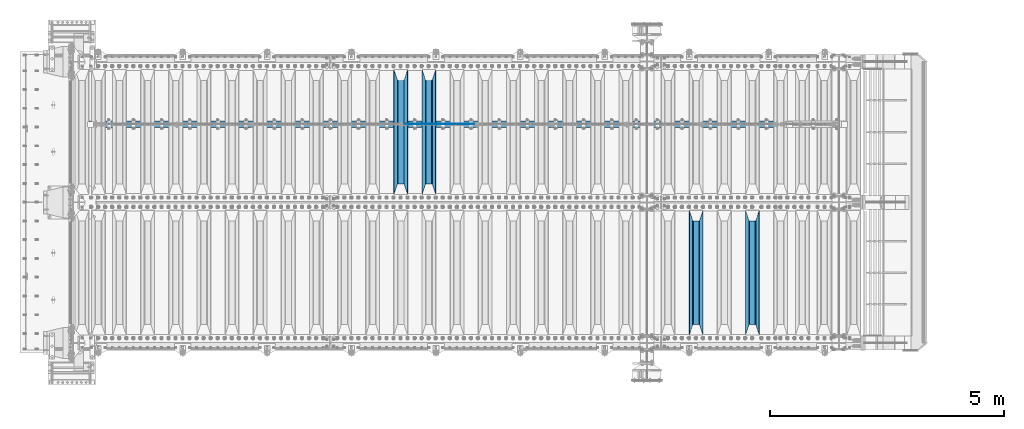
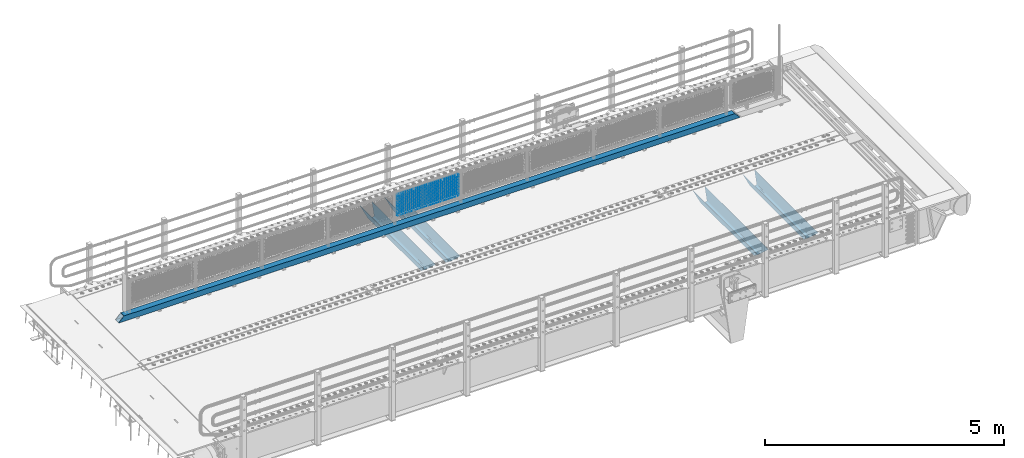
# One storey, part 102 of 208: 22 beams.
"""IFC2X3 building model written with IfcOpenShell, lengths in millimetres."""

from ifc_helpers import new_model, si_unit, frame, origin_with_axes, place, context, subcontext, project, spatial, faceted_brep, material, type_object, element, save


model = new_model("IFC2X3")

# Units and contexts
model_context = context("Model", 3, precision=1e-05, world=origin_with_axes())
body_context = subcontext(model_context, "Body", "Model", "MODEL_VIEW")
ifc_project = project(units=[si_unit("LENGTHUNIT", "METRE", prefix="MILLI"), si_unit("AREAUNIT", "SQUARE_METRE"), si_unit("VOLUMEUNIT", "CUBIC_METRE"), si_unit("MASSUNIT", "GRAM", prefix="KILO"), si_unit("TIMEUNIT", "SECOND"), si_unit("PLANEANGLEUNIT", "RADIAN"), si_unit("SOLIDANGLEUNIT", "STERADIAN"), si_unit("THERMODYNAMICTEMPERATUREUNIT", "DEGREE_CELSIUS"), si_unit("LUMINOUSINTENSITYUNIT", "LUMEN")], contexts=[model_context])

# Site, building, storey
site_placement = place(None, origin_with_axes())
site = spatial("IfcSite", under=ifc_project, at=site_placement, CompositionType="ELEMENT")
building_placement = place(site_placement, origin_with_axes())
building = spatial("IfcBuilding", under=site, at=building_placement, Name="Standard", CompositionType="ELEMENT")
storey_placement = place(building_placement, origin_with_axes())
storey = spatial("IfcBuildingStorey", under=building, at=storey_placement, Name="Undefined", CompositionType="ELEMENT", Elevation=0.0)

# Beams
ifc_material_1 = material(Name="STEEL/S355N")
beam_type_1 = type_object("IfcBeamType", PredefinedType="NOTDEFINED")
beam_1_placement = place(storey_placement, frame((-27950.0, 175.0, -115.0), z_axis=(0.0, 0.0, 1.0), x_axis=(0.0, 1.0, 0.0)))
element("IfcBeam", 1, at=beam_1_placement, inside=storey, type_object=beam_type_1, material=ifc_material_1, context=body_context, shape_type="Brep", body=[
    faceted_brep([(0.0, 150.0, 115.0), (0.0, 143.689999999999, 115.0), (2650.00000000297, 143.689999999999, 115.0), (2650.00000000297, 150.0, 115.0), (2650.00000000297, 142.059565218402, 110.0000000031), (2650.00000000297, 148.369565218403, 110.0000000031), (2441.90079219208, -80.1103600731112, -98.0992078077845), (2437.7588105432, -77.5672621345584, -102.241189456673), (2434.06523489746, -74.4080125315522, -105.934765102404), (2430.91086095089, -70.710272125576, -109.089139048974), (2428.37322971128, -66.5649389910068, -111.626770288588), (2426.51472138055, -62.0739139532889, -113.485278619323), (2425.38102192091, -57.3475956567672, -114.618978078955), (2424.99999999987, -52.5021667386536, -115.0), (2424.99999999987, 52.5021667386536, -115.0), (2425.38102192091, 57.3475956567672, -114.618978078955), (2426.51472138055, 62.0739139532889, -113.485278619323), (2428.37322971128, 66.5649389910068, -111.626770288588), (2430.91086095089, 70.710272125576, -109.089139048974), (2434.06523489746, 74.4080125315522, -105.934765102404), (2437.7588105432, 77.5672621345584, -102.241189456673), (2441.90079219208, 80.1103600731112, -98.0992078077846), (2446.38936140511, 81.9747917625791, -93.6106385947584), (2448.24948500409, 76.2713538057251, -91.7505149957729), (2444.62967112262, 74.76777986261, -95.3703288772456), (2441.28936334126, 72.7168944282894, -98.710636658607), (2438.31067330438, 70.1691124903846, -101.689326695487), (2435.76682334747, 67.1870637758839, -104.233176652398), (2433.72034654133, 63.8440531834895, -106.279653458539), (2432.22154950041, 60.222258798236, -107.778450499454), (2431.30727574265, 56.4107117849089, -108.692724257221), (2430.99999999987, 52.5031078186876, -109.0), (2430.99999999987, -52.5031078186876, -109.0), (2431.30727574265, -56.4107117849089, -108.692724257221), (2432.22154950041, -60.222258798236, -107.778450499454), (2433.72034654133, -63.8440531834895, -106.279653458539), (2435.76682334747, -67.1870637758839, -104.233176652398), (2438.31067330438, -70.1691124903846, -101.689326695487), (2441.28936334126, -72.7168944282894, -98.7106366586071), (2444.62967112262, -74.76777986261, -95.3703288772457), (2448.24948500409, -76.2713538057251, -91.7505149957729), (2650.00000000297, -142.059565218402, 110.0000000031), (2650.00000000297, -148.369565218403, 110.0000000031), (2446.38936140511, -81.9747917625791, -93.6106385947584), (2650.00000000297, -143.689999999999, 115.0), (2650.00000000297, -150.0, 115.0), (0.0, -143.689999999999, 115.0), (0.0, -150.0, 115.0), (0.0, -148.369565218261, 110.000000002663), (203.610638597421, -81.9747917625791, -93.6106385947584), (208.099207810448, -80.1103600731112, -98.0992078077845), (212.241189459336, -77.5672621345584, -102.241189456673), (215.934765105067, -74.4080125315522, -105.934765102404), (219.089139051637, -70.710272125576, -109.089139048974), (221.626770291251, -66.5649389910068, -111.626770288588), (223.485278621986, -62.0739139532889, -113.485278619323), (224.618978081618, -57.3475956567672, -114.618978078955), (225.000000002663, -52.5021667386536, -115.0), (225.000000002663, 52.5021667386536, -115.0), (224.618978081618, 57.3475956567672, -114.618978078955), (223.485278621986, 62.0739139532889, -113.485278619323), (221.626770291251, 66.5649389910068, -111.626770288588), (219.089139051637, 70.710272125576, -109.089139048974), (215.934765105067, 74.4080125315522, -105.934765102404), (212.241189459336, 77.5672621345584, -102.241189456673), (208.099207810448, 80.1103600731112, -98.0992078077846), (203.610638597421, 81.9747917625791, -93.6106385947584), (0.0, 148.369565218261, 110.000000002663), (0.0, 142.05956521826, 110.000000002663), (201.750514998436, 76.2713538057251, -91.7505149957729), (205.370328879908, 74.76777986261, -95.3703288772456), (208.71063666127, 72.7168944282894, -98.710636658607), (211.68932669815, 70.1691124903846, -101.689326695487), (214.233176655061, 67.1870637758839, -104.233176652398), (216.279653461202, 63.8440531834895, -106.279653458539), (217.778450502116, 60.222258798236, -107.778450499454), (218.692724259884, 56.4107117849089, -108.692724257221), (219.000000002663, 52.5031078186876, -109.0), (219.000000002663, -52.5031078186876, -109.0), (218.692724259884, -56.4107117849089, -108.692724257221), (217.778450502116, -60.222258798236, -107.778450499454), (216.279653461202, -63.8440531834895, -106.279653458539), (214.233176655061, -67.1870637758839, -104.233176652398), (211.68932669815, -70.1691124903846, -101.689326695487), (208.71063666127, -72.7168944282894, -98.7106366586071), (205.370328879908, -74.76777986261, -95.3703288772457), (201.750514998436, -76.2713538057251, -91.7505149957729), (0.0, -142.05956521826, 110.000000002663)], [[[0, 1, 2, 3]], [[3, 2, 4, 5]], [[6, 7, 8, 9, 10, 11, 12, 13, 14, 15, 16, 17, 18, 19, 20, 21, 22, 5, 4, 23, 24, 25, 26, 27, 28, 29, 30, 31, 32, 33, 34, 35, 36, 37, 38, 39, 40, 41, 42, 43]], [[44, 45, 42, 41]], [[46, 47, 45, 44]], [[43, 42, 45, 47, 48, 49]], [[6, 43, 49, 50]], [[7, 6, 50, 51]], [[8, 7, 51, 52]], [[9, 8, 52, 53]], [[10, 9, 53, 54]], [[11, 10, 54, 55]], [[12, 11, 55, 56]], [[13, 12, 56, 57]], [[14, 13, 57, 58]], [[15, 14, 58, 59]], [[16, 15, 59, 60]], [[17, 16, 60, 61]], [[18, 17, 61, 62]], [[19, 18, 62, 63]], [[20, 19, 63, 64]], [[21, 20, 64, 65]], [[22, 21, 65, 66]], [[0, 3, 5, 22, 66, 67]], [[1, 0, 67, 68]], [[23, 4, 2, 1, 68, 69]], [[24, 23, 69, 70]], [[25, 24, 70, 71]], [[26, 25, 71, 72]], [[27, 26, 72, 73]], [[28, 27, 73, 74]], [[29, 28, 74, 75]], [[30, 29, 75, 76]], [[31, 30, 76, 77]], [[32, 31, 77, 78]], [[33, 32, 78, 79]], [[34, 33, 79, 80]], [[35, 34, 80, 81]], [[36, 35, 81, 82]], [[37, 36, 82, 83]], [[38, 37, 83, 84]], [[39, 38, 84, 85]], [[40, 39, 85, 86]], [[46, 44, 41, 40, 86, 87]], [[47, 46, 87, 48]], [[86, 85, 84, 83, 82, 81, 80, 79, 78, 77, 76, 75, 74, 73, 72, 71, 70, 69, 68, 67, 66, 65, 64, 63, 62, 61, 60, 59, 58, 57, 56, 55, 54, 53, 52, 51, 50, 49, 48, 87]]]),
])
beam_2_placement = place(storey_placement, frame((-29150.0, 175.0, -115.0), z_axis=(0.0, 0.0, 1.0), x_axis=(0.0, 1.0, 0.0)))
element("IfcBeam", 2, at=beam_2_placement, inside=storey, type_object=beam_type_1, material=ifc_material_1, context=body_context, shape_type="Brep", body=[
    faceted_brep([(0.0, 150.0, 115.0), (0.0, 143.689999999999, 115.0), (2650.00000000297, 143.689999999999, 115.0), (2650.00000000297, 150.0, 115.0), (2650.00000000297, 142.059565218402, 110.0000000031), (2650.00000000297, 148.369565218403, 110.0000000031), (2441.90079219208, -80.1103600731112, -98.0992078077845), (2437.7588105432, -77.5672621345584, -102.241189456673), (2434.06523489746, -74.4080125315522, -105.934765102404), (2430.91086095089, -70.710272125576, -109.089139048974), (2428.37322971128, -66.5649389910068, -111.626770288588), (2426.51472138055, -62.0739139532889, -113.485278619323), (2425.38102192091, -57.3475956567672, -114.618978078955), (2424.99999999987, -52.5021667386536, -115.0), (2424.99999999987, 52.5021667386536, -115.0), (2425.38102192091, 57.3475956567672, -114.618978078955), (2426.51472138055, 62.0739139532889, -113.485278619323), (2428.37322971128, 66.5649389910068, -111.626770288588), (2430.91086095089, 70.710272125576, -109.089139048974), (2434.06523489746, 74.4080125315522, -105.934765102404), (2437.7588105432, 77.5672621345584, -102.241189456673), (2441.90079219208, 80.1103600731112, -98.0992078077846), (2446.38936140511, 81.9747917625791, -93.6106385947584), (2448.24948500409, 76.2713538057251, -91.7505149957729), (2444.62967112262, 74.76777986261, -95.3703288772456), (2441.28936334126, 72.7168944282894, -98.710636658607), (2438.31067330438, 70.1691124903846, -101.689326695487), (2435.76682334747, 67.1870637758839, -104.233176652398), (2433.72034654133, 63.8440531834895, -106.279653458539), (2432.22154950041, 60.222258798236, -107.778450499454), (2431.30727574265, 56.4107117849089, -108.692724257221), (2430.99999999987, 52.5031078186876, -109.0), (2430.99999999987, -52.5031078186876, -109.0), (2431.30727574265, -56.4107117849089, -108.692724257221), (2432.22154950041, -60.222258798236, -107.778450499454), (2433.72034654133, -63.8440531834895, -106.279653458539), (2435.76682334747, -67.1870637758839, -104.233176652398), (2438.31067330438, -70.1691124903846, -101.689326695487), (2441.28936334126, -72.7168944282894, -98.7106366586071), (2444.62967112262, -74.76777986261, -95.3703288772457), (2448.24948500409, -76.2713538057251, -91.7505149957729), (2650.00000000297, -142.059565218402, 110.0000000031), (2650.00000000297, -148.369565218403, 110.0000000031), (2446.38936140511, -81.9747917625791, -93.6106385947584), (2650.00000000297, -143.689999999999, 115.0), (2650.00000000297, -150.0, 115.0), (0.0, -143.689999999999, 115.0), (0.0, -150.0, 115.0), (0.0, -148.369565218261, 110.000000002663), (203.610638597421, -81.9747917625791, -93.6106385947584), (208.099207810448, -80.1103600731112, -98.0992078077845), (212.241189459336, -77.5672621345584, -102.241189456673), (215.934765105067, -74.4080125315522, -105.934765102404), (219.089139051637, -70.710272125576, -109.089139048974), (221.626770291251, -66.5649389910068, -111.626770288588), (223.485278621986, -62.0739139532889, -113.485278619323), (224.618978081618, -57.3475956567672, -114.618978078955), (225.000000002663, -52.5021667386536, -115.0), (225.000000002663, 52.5021667386536, -115.0), (224.618978081618, 57.3475956567672, -114.618978078955), (223.485278621986, 62.0739139532889, -113.485278619323), (221.626770291251, 66.5649389910068, -111.626770288588), (219.089139051637, 70.710272125576, -109.089139048974), (215.934765105067, 74.4080125315522, -105.934765102404), (212.241189459336, 77.5672621345584, -102.241189456673), (208.099207810448, 80.1103600731112, -98.0992078077846), (203.610638597421, 81.9747917625791, -93.6106385947584), (0.0, 148.369565218261, 110.000000002663), (0.0, 142.05956521826, 110.000000002663), (201.750514998436, 76.2713538057251, -91.7505149957729), (205.370328879908, 74.76777986261, -95.3703288772456), (208.71063666127, 72.7168944282894, -98.710636658607), (211.68932669815, 70.1691124903846, -101.689326695487), (214.233176655061, 67.1870637758839, -104.233176652398), (216.279653461202, 63.8440531834895, -106.279653458539), (217.778450502116, 60.222258798236, -107.778450499454), (218.692724259884, 56.4107117849089, -108.692724257221), (219.000000002663, 52.5031078186876, -109.0), (219.000000002663, -52.5031078186876, -109.0), (218.692724259884, -56.4107117849089, -108.692724257221), (217.778450502116, -60.222258798236, -107.778450499454), (216.279653461202, -63.8440531834895, -106.279653458539), (214.233176655061, -67.1870637758839, -104.233176652398), (211.68932669815, -70.1691124903846, -101.689326695487), (208.71063666127, -72.7168944282894, -98.7106366586071), (205.370328879908, -74.76777986261, -95.3703288772457), (201.750514998436, -76.2713538057251, -91.7505149957729), (0.0, -142.05956521826, 110.000000002663)], [[[0, 1, 2, 3]], [[3, 2, 4, 5]], [[6, 7, 8, 9, 10, 11, 12, 13, 14, 15, 16, 17, 18, 19, 20, 21, 22, 5, 4, 23, 24, 25, 26, 27, 28, 29, 30, 31, 32, 33, 34, 35, 36, 37, 38, 39, 40, 41, 42, 43]], [[44, 45, 42, 41]], [[46, 47, 45, 44]], [[43, 42, 45, 47, 48, 49]], [[6, 43, 49, 50]], [[7, 6, 50, 51]], [[8, 7, 51, 52]], [[9, 8, 52, 53]], [[10, 9, 53, 54]], [[11, 10, 54, 55]], [[12, 11, 55, 56]], [[13, 12, 56, 57]], [[14, 13, 57, 58]], [[15, 14, 58, 59]], [[16, 15, 59, 60]], [[17, 16, 60, 61]], [[18, 17, 61, 62]], [[19, 18, 62, 63]], [[20, 19, 63, 64]], [[21, 20, 64, 65]], [[22, 21, 65, 66]], [[0, 3, 5, 22, 66, 67]], [[1, 0, 67, 68]], [[23, 4, 2, 1, 68, 69]], [[24, 23, 69, 70]], [[25, 24, 70, 71]], [[26, 25, 71, 72]], [[27, 26, 72, 73]], [[28, 27, 73, 74]], [[29, 28, 74, 75]], [[30, 29, 75, 76]], [[31, 30, 76, 77]], [[32, 31, 77, 78]], [[33, 32, 78, 79]], [[34, 33, 79, 80]], [[35, 34, 80, 81]], [[36, 35, 81, 82]], [[37, 36, 82, 83]], [[38, 37, 83, 84]], [[39, 38, 84, 85]], [[40, 39, 85, 86]], [[46, 44, 41, 40, 86, 87]], [[47, 46, 87, 48]], [[86, 85, 84, 83, 82, 81, 80, 79, 78, 77, 76, 75, 74, 73, 72, 71, 70, 69, 68, 67, 66, 65, 64, 63, 62, 61, 60, 59, 58, 57, 56, 55, 54, 53, 52, 51, 50, 49, 48, 87]]]),
])
beam_3_placement = place(storey_placement, frame((-34850.0, 3175.0, -115.0), z_axis=(0.0, 0.0, 1.0), x_axis=(0.0, 1.0, 0.0)))
element("IfcBeam", 3, at=beam_3_placement, inside=storey, type_object=beam_type_1, material=ifc_material_1, context=body_context, shape_type="Brep", body=[
    faceted_brep([(0.0, 150.0, 115.0), (0.0, 143.689999999999, 115.0), (2650.00000000297, 143.689999999999, 115.0), (2650.00000000297, 150.0, 115.0), (2650.00000000297, 142.059565218402, 110.0000000031), (2650.00000000297, 148.369565218403, 110.0000000031), (2441.90079219208, -80.1103600731112, -98.0992078077845), (2437.7588105432, -77.5672621345584, -102.241189456673), (2434.06523489746, -74.4080125315522, -105.934765102404), (2430.91086095089, -70.710272125576, -109.089139048974), (2428.37322971128, -66.5649389910068, -111.626770288588), (2426.51472138055, -62.0739139532889, -113.485278619323), (2425.38102192091, -57.3475956567672, -114.618978078955), (2424.99999999987, -52.5021667386536, -115.0), (2424.99999999987, 52.5021667386536, -115.0), (2425.38102192091, 57.3475956567672, -114.618978078955), (2426.51472138055, 62.0739139532889, -113.485278619323), (2428.37322971128, 66.5649389910068, -111.626770288588), (2430.91086095089, 70.710272125576, -109.089139048974), (2434.06523489746, 74.4080125315522, -105.934765102404), (2437.7588105432, 77.5672621345584, -102.241189456673), (2441.90079219208, 80.1103600731112, -98.0992078077846), (2446.38936140511, 81.9747917625791, -93.6106385947584), (2448.24948500409, 76.2713538057251, -91.7505149957729), (2444.62967112262, 74.76777986261, -95.3703288772456), (2441.28936334126, 72.7168944282894, -98.710636658607), (2438.31067330438, 70.1691124903846, -101.689326695487), (2435.76682334747, 67.1870637758839, -104.233176652398), (2433.72034654133, 63.8440531834895, -106.279653458539), (2432.22154950041, 60.222258798236, -107.778450499454), (2431.30727574265, 56.4107117849089, -108.692724257221), (2430.99999999987, 52.5031078186876, -109.0), (2430.99999999987, -52.5031078186876, -109.0), (2431.30727574265, -56.4107117849089, -108.692724257221), (2432.22154950041, -60.222258798236, -107.778450499454), (2433.72034654133, -63.8440531834895, -106.279653458539), (2435.76682334747, -67.1870637758839, -104.233176652398), (2438.31067330438, -70.1691124903846, -101.689326695487), (2441.28936334126, -72.7168944282894, -98.7106366586071), (2444.62967112262, -74.76777986261, -95.3703288772457), (2448.24948500409, -76.2713538057251, -91.7505149957729), (2650.00000000297, -142.059565218402, 110.0000000031), (2650.00000000297, -148.369565218403, 110.0000000031), (2446.38936140511, -81.9747917625791, -93.6106385947584), (2650.00000000297, -143.689999999999, 115.0), (2650.00000000297, -150.0, 115.0), (0.0, -143.689999999999, 115.0), (0.0, -150.0, 115.0), (0.0, -148.369565218261, 110.000000002663), (203.610638597421, -81.9747917625791, -93.6106385947584), (208.099207810448, -80.1103600731112, -98.0992078077845), (212.241189459336, -77.5672621345584, -102.241189456673), (215.934765105067, -74.4080125315522, -105.934765102404), (219.089139051637, -70.710272125576, -109.089139048974), (221.626770291251, -66.5649389910068, -111.626770288588), (223.485278621986, -62.0739139532889, -113.485278619323), (224.618978081618, -57.3475956567672, -114.618978078955), (225.000000002663, -52.5021667386536, -115.0), (225.000000002663, 52.5021667386536, -115.0), (224.618978081618, 57.3475956567672, -114.618978078955), (223.485278621986, 62.0739139532889, -113.485278619323), (221.626770291251, 66.5649389910068, -111.626770288588), (219.089139051637, 70.710272125576, -109.089139048974), (215.934765105067, 74.4080125315522, -105.934765102404), (212.241189459336, 77.5672621345584, -102.241189456673), (208.099207810448, 80.1103600731112, -98.0992078077846), (203.610638597421, 81.9747917625791, -93.6106385947584), (0.0, 148.369565218261, 110.000000002663), (0.0, 142.05956521826, 110.000000002663), (201.750514998436, 76.2713538057251, -91.7505149957729), (205.370328879908, 74.76777986261, -95.3703288772456), (208.71063666127, 72.7168944282894, -98.710636658607), (211.68932669815, 70.1691124903846, -101.689326695487), (214.233176655061, 67.1870637758839, -104.233176652398), (216.279653461202, 63.8440531834895, -106.279653458539), (217.778450502116, 60.222258798236, -107.778450499454), (218.692724259884, 56.4107117849089, -108.692724257221), (219.000000002663, 52.5031078186876, -109.0), (219.000000002663, -52.5031078186876, -109.0), (218.692724259884, -56.4107117849089, -108.692724257221), (217.778450502116, -60.222258798236, -107.778450499454), (216.279653461202, -63.8440531834895, -106.279653458539), (214.233176655061, -67.1870637758839, -104.233176652398), (211.68932669815, -70.1691124903846, -101.689326695487), (208.71063666127, -72.7168944282894, -98.7106366586071), (205.370328879908, -74.76777986261, -95.3703288772457), (201.750514998436, -76.2713538057251, -91.7505149957729), (0.0, -142.05956521826, 110.000000002663)], [[[0, 1, 2, 3]], [[3, 2, 4, 5]], [[6, 7, 8, 9, 10, 11, 12, 13, 14, 15, 16, 17, 18, 19, 20, 21, 22, 5, 4, 23, 24, 25, 26, 27, 28, 29, 30, 31, 32, 33, 34, 35, 36, 37, 38, 39, 40, 41, 42, 43]], [[44, 45, 42, 41]], [[46, 47, 45, 44]], [[43, 42, 45, 47, 48, 49]], [[6, 43, 49, 50]], [[7, 6, 50, 51]], [[8, 7, 51, 52]], [[9, 8, 52, 53]], [[10, 9, 53, 54]], [[11, 10, 54, 55]], [[12, 11, 55, 56]], [[13, 12, 56, 57]], [[14, 13, 57, 58]], [[15, 14, 58, 59]], [[16, 15, 59, 60]], [[17, 16, 60, 61]], [[18, 17, 61, 62]], [[19, 18, 62, 63]], [[20, 19, 63, 64]], [[21, 20, 64, 65]], [[22, 21, 65, 66]], [[0, 3, 5, 22, 66, 67]], [[1, 0, 67, 68]], [[23, 4, 2, 1, 68, 69]], [[24, 23, 69, 70]], [[25, 24, 70, 71]], [[26, 25, 71, 72]], [[27, 26, 72, 73]], [[28, 27, 73, 74]], [[29, 28, 74, 75]], [[30, 29, 75, 76]], [[31, 30, 76, 77]], [[32, 31, 77, 78]], [[33, 32, 78, 79]], [[34, 33, 79, 80]], [[35, 34, 80, 81]], [[36, 35, 81, 82]], [[37, 36, 82, 83]], [[38, 37, 83, 84]], [[39, 38, 84, 85]], [[40, 39, 85, 86]], [[46, 44, 41, 40, 86, 87]], [[47, 46, 87, 48]], [[86, 85, 84, 83, 82, 81, 80, 79, 78, 77, 76, 75, 74, 73, 72, 71, 70, 69, 68, 67, 66, 65, 64, 63, 62, 61, 60, 59, 58, 57, 56, 55, 54, 53, 52, 51, 50, 49, 48, 87]]]),
])
beam_4_placement = place(storey_placement, frame((-35450.0, 3175.0, -115.0), z_axis=(0.0, 0.0, 1.0), x_axis=(0.0, 1.0, 0.0)))
element("IfcBeam", 4, at=beam_4_placement, inside=storey, type_object=beam_type_1, material=ifc_material_1, context=body_context, shape_type="Brep", body=[
    faceted_brep([(0.0, 150.0, 115.0), (0.0, 143.689999999999, 115.0), (2650.00000000297, 143.689999999999, 115.0), (2650.00000000297, 150.0, 115.0), (2650.00000000297, 142.059565218402, 110.0000000031), (2650.00000000297, 148.369565218403, 110.0000000031), (2441.90079219208, -80.1103600731112, -98.0992078077845), (2437.7588105432, -77.5672621345584, -102.241189456673), (2434.06523489746, -74.4080125315522, -105.934765102404), (2430.91086095089, -70.710272125576, -109.089139048974), (2428.37322971128, -66.5649389910068, -111.626770288588), (2426.51472138055, -62.0739139532889, -113.485278619323), (2425.38102192091, -57.3475956567672, -114.618978078955), (2424.99999999987, -52.5021667386536, -115.0), (2424.99999999987, 52.5021667386536, -115.0), (2425.38102192091, 57.3475956567672, -114.618978078955), (2426.51472138055, 62.0739139532889, -113.485278619323), (2428.37322971128, 66.5649389910068, -111.626770288588), (2430.91086095089, 70.710272125576, -109.089139048974), (2434.06523489746, 74.4080125315522, -105.934765102404), (2437.7588105432, 77.5672621345584, -102.241189456673), (2441.90079219208, 80.1103600731112, -98.0992078077846), (2446.38936140511, 81.9747917625791, -93.6106385947584), (2448.24948500409, 76.2713538057251, -91.7505149957729), (2444.62967112262, 74.76777986261, -95.3703288772456), (2441.28936334126, 72.7168944282894, -98.710636658607), (2438.31067330438, 70.1691124903846, -101.689326695487), (2435.76682334747, 67.1870637758839, -104.233176652398), (2433.72034654133, 63.8440531834895, -106.279653458539), (2432.22154950041, 60.222258798236, -107.778450499454), (2431.30727574265, 56.4107117849089, -108.692724257221), (2430.99999999987, 52.5031078186876, -109.0), (2430.99999999987, -52.5031078186876, -109.0), (2431.30727574265, -56.4107117849089, -108.692724257221), (2432.22154950041, -60.222258798236, -107.778450499454), (2433.72034654133, -63.8440531834895, -106.279653458539), (2435.76682334747, -67.1870637758839, -104.233176652398), (2438.31067330438, -70.1691124903846, -101.689326695487), (2441.28936334126, -72.7168944282894, -98.7106366586071), (2444.62967112262, -74.76777986261, -95.3703288772457), (2448.24948500409, -76.2713538057251, -91.7505149957729), (2650.00000000297, -142.059565218402, 110.0000000031), (2650.00000000297, -148.369565218403, 110.0000000031), (2446.38936140511, -81.9747917625791, -93.6106385947584), (2650.00000000297, -143.689999999999, 115.0), (2650.00000000297, -150.0, 115.0), (0.0, -143.689999999999, 115.0), (0.0, -150.0, 115.0), (0.0, -148.369565218261, 110.000000002663), (203.610638597421, -81.9747917625791, -93.6106385947584), (208.099207810448, -80.1103600731112, -98.0992078077845), (212.241189459336, -77.5672621345584, -102.241189456673), (215.934765105067, -74.4080125315522, -105.934765102404), (219.089139051637, -70.710272125576, -109.089139048974), (221.626770291251, -66.5649389910068, -111.626770288588), (223.485278621986, -62.0739139532889, -113.485278619323), (224.618978081618, -57.3475956567672, -114.618978078955), (225.000000002663, -52.5021667386536, -115.0), (225.000000002663, 52.5021667386536, -115.0), (224.618978081618, 57.3475956567672, -114.618978078955), (223.485278621986, 62.0739139532889, -113.485278619323), (221.626770291251, 66.5649389910068, -111.626770288588), (219.089139051637, 70.710272125576, -109.089139048974), (215.934765105067, 74.4080125315522, -105.934765102404), (212.241189459336, 77.5672621345584, -102.241189456673), (208.099207810448, 80.1103600731112, -98.0992078077846), (203.610638597421, 81.9747917625791, -93.6106385947584), (0.0, 148.369565218261, 110.000000002663), (0.0, 142.05956521826, 110.000000002663), (201.750514998436, 76.2713538057251, -91.7505149957729), (205.370328879908, 74.76777986261, -95.3703288772456), (208.71063666127, 72.7168944282894, -98.710636658607), (211.68932669815, 70.1691124903846, -101.689326695487), (214.233176655061, 67.1870637758839, -104.233176652398), (216.279653461202, 63.8440531834895, -106.279653458539), (217.778450502116, 60.222258798236, -107.778450499454), (218.692724259884, 56.4107117849089, -108.692724257221), (219.000000002663, 52.5031078186876, -109.0), (219.000000002663, -52.5031078186876, -109.0), (218.692724259884, -56.4107117849089, -108.692724257221), (217.778450502116, -60.222258798236, -107.778450499454), (216.279653461202, -63.8440531834895, -106.279653458539), (214.233176655061, -67.1870637758839, -104.233176652398), (211.68932669815, -70.1691124903846, -101.689326695487), (208.71063666127, -72.7168944282894, -98.7106366586071), (205.370328879908, -74.76777986261, -95.3703288772457), (201.750514998436, -76.2713538057251, -91.7505149957729), (0.0, -142.05956521826, 110.000000002663)], [[[0, 1, 2, 3]], [[3, 2, 4, 5]], [[6, 7, 8, 9, 10, 11, 12, 13, 14, 15, 16, 17, 18, 19, 20, 21, 22, 5, 4, 23, 24, 25, 26, 27, 28, 29, 30, 31, 32, 33, 34, 35, 36, 37, 38, 39, 40, 41, 42, 43]], [[44, 45, 42, 41]], [[46, 47, 45, 44]], [[43, 42, 45, 47, 48, 49]], [[6, 43, 49, 50]], [[7, 6, 50, 51]], [[8, 7, 51, 52]], [[9, 8, 52, 53]], [[10, 9, 53, 54]], [[11, 10, 54, 55]], [[12, 11, 55, 56]], [[13, 12, 56, 57]], [[14, 13, 57, 58]], [[15, 14, 58, 59]], [[16, 15, 59, 60]], [[17, 16, 60, 61]], [[18, 17, 61, 62]], [[19, 18, 62, 63]], [[20, 19, 63, 64]], [[21, 20, 64, 65]], [[22, 21, 65, 66]], [[0, 3, 5, 22, 66, 67]], [[1, 0, 67, 68]], [[23, 4, 2, 1, 68, 69]], [[24, 23, 69, 70]], [[25, 24, 70, 71]], [[26, 25, 71, 72]], [[27, 26, 72, 73]], [[28, 27, 73, 74]], [[29, 28, 74, 75]], [[30, 29, 75, 76]], [[31, 30, 76, 77]], [[32, 31, 77, 78]], [[33, 32, 78, 79]], [[34, 33, 79, 80]], [[35, 34, 80, 81]], [[36, 35, 81, 82]], [[37, 36, 82, 83]], [[38, 37, 83, 84]], [[39, 38, 84, 85]], [[40, 39, 85, 86]], [[46, 44, 41, 40, 86, 87]], [[47, 46, 87, 48]], [[86, 85, 84, 83, 82, 81, 80, 79, 78, 77, 76, 75, 74, 73, 72, 71, 70, 69, 68, 67, 66, 65, 64, 63, 62, 61, 60, 59, 58, 57, 56, 55, 54, 53, 52, 51, 50, 49, 48, 87]]]),
])
ifc_material_2 = material()
beam_type_2 = type_object("IfcBeamType", PredefinedType="NOTDEFINED")
beam_5_placement = place(storey_placement, frame((-42125.0, 4664.5, 98.0199999999977), z_axis=(0.0, 0.0, 1.0), x_axis=(1.0, 0.0, 0.0)))
element("IfcBeam", 5, at=beam_5_placement, inside=storey, type_object=beam_type_2, material=ifc_material_2, context=body_context, shape_type="Brep", body=[
    faceted_brep([(0.0, -70.0, -70.0), (0.0, 70.0, -70.0), (14992.0, 70.0, -70.0), (14992.0, -70.0, -70.0), (14861.8884698478, -70.0, 70.0), (14861.8884698478, 70.0, 70.0), (130.111530936148, 70.0, 70.0), (130.111528976151, -70.0, 70.0), (14992.0, -70.0, -60.0079600980746), (0.0, -70.0, -60.0079591069155), (14871.8964362873, -60.0, 60.0), (14992.0, -60.0, -60.0), (0.0, -60.0, -60.0), (120.103562690863, -60.0, 60.0), (14871.8964362873, 60.0, 60.0), (120.10356437086, 60.0, 60.0), (14992.0, 60.0, -60.0), (0.0, 60.0, -60.0), (14992.0, 70.0, -60.0079600980746), (0.0, 70.0, -60.0079610653521)], [[[0, 1, 2, 3]], [[4, 5, 6, 7]], [[0, 3, 8, 4, 7, 9]], [[10, 11, 12, 13]], [[14, 10, 13, 15]], [[16, 14, 15, 17]], [[4, 8, 11, 10, 14, 16, 18, 5]], [[11, 8, 3, 2, 18, 16]], [[17, 12, 11, 16]], [[1, 0, 9, 12, 17, 19]], [[5, 18, 2, 1, 19, 6]], [[17, 15, 13, 12, 9, 7, 6, 19]]]),
])
ifc_material_3 = material(Name="Misc_Undefined")
beam_type_3 = type_object("IfcBeamType", Name="D3", PredefinedType="NOTDEFINED")
for number, where, z_axis, x_axis in (
    (6, (-35374.0, 4670.5, 851.597000000002), (0.0, 0.0, 1.0), (1.0, 0.0, 0.0)),
    (7, (-35374.0, 4670.5, 669.452000000002), (0.0, 0.0, 1.0), (1.0, 0.0, 0.0)),
    (8, (-35374.0, 4670.5, 523.736000000002), (0.0, 0.0, 1.0), (1.0, 0.0, 0.0)),
    (9, (-35374.0, 4670.5, 487.307000000002), (0.0, 0.0, 1.0), (1.0, 0.0, 0.0)),
    (10, (-35374.0, 4670.5, 705.881000000002), (0.0, 0.0, 1.0), (1.0, 0.0, 0.0)),
    (11, (-35374.0, 4670.5, 596.594000000002), (0.0, 0.0, 1.0), (1.0, 0.0, 0.0)),
    (12, (-35374.0, 4670.5, 450.878000000002), (0.0, 0.0, 1.0), (1.0, 0.0, 0.0)),
    (13, (-35374.0, 4670.5, 815.168000000002), (0.0, 0.0, 1.0), (1.0, 0.0, 0.0)),
    (14, (-35374.0, 4670.5, 888.026000000002), (0.0, 0.0, 1.0), (1.0, 0.0, 0.0)),
    (15, (-35374.0, 4670.5, 778.739000000002), (0.0, 0.0, 1.0), (1.0, 0.0, 0.0)),
    (16, (-35374.0, 4670.5, 742.310000000002), (0.0, 0.0, 1.0), (1.0, 0.0, 0.0)),
    (17, (-35374.0, 4670.5, 633.023000000002), (0.0, 0.0, 1.0), (1.0, 0.0, 0.0)),
    (18, (-35374.0, 4670.5, 560.165000000002), (0.0, 0.0, 1.0), (1.0, 0.0, 0.0)),
    (19, (-35374.0, 4670.5, 414.449000000002), (0.0, 0.0, 1.0), (1.0, 0.0, 0.0)),
):
    element("IfcBeam", number, at=place(storey_placement, frame(where, z_axis=z_axis, x_axis=x_axis)), inside=storey, type_object=beam_type_3, material=ifc_material_3, ObjectType="D3", context=body_context, shape_type="Brep", body=[
        faceted_brep([(0.0, -1.49999999999909, 3.63797880709171e-12), (-7.27595761418343e-12, -0.749999999999091, -1.29903810567669), (1490.0, -0.75, -1.29903810567669), (1490.0, -1.5, 0.0), (-3.63797880709171e-12, 0.750000000000909, -1.29903810567669), (1490.0, 0.75, -1.29903810567669), (0.0, 1.50000000000182, 3.63797880709171e-12), (1490.0, 1.5, 0.0), (-3.63797880709171e-12, 0.750000000000909, 1.29903810567669), (1490.0, 0.75, 1.29903810567669), (-7.27595761418343e-12, -0.749999999999091, 1.29903810567669), (1490.0, -0.75, 1.29903810567669)], [[[0, 1, 2, 3]], [[1, 4, 5, 2]], [[4, 6, 7, 5]], [[6, 8, 9, 7]], [[8, 10, 11, 9]], [[10, 0, 3, 11]], [[5, 7, 9, 11, 3, 2]], [[10, 8, 6, 4, 1, 0]]]),
    ])
beam_6_placement = place(storey_placement, frame((-35349.0, 4670.5, 353.020000000002), z_axis=(0.0, 0.0, 1.0), x_axis=(1.0, 0.0, 0.0)))
element("IfcBeam", 20, at=beam_6_placement, inside=storey, type_object=beam_type_3, material=ifc_material_3, ObjectType="D3", context=body_context, shape_type="Brep", body=[
    faceted_brep([(0.0, -1.49999999999909, 3.63797880709171e-12), (-7.27595761418343e-12, -0.749999999999091, -1.29903810567669), (1440.0, -0.75, -1.29903810567669), (1440.0, -1.5, 0.0), (-3.63797880709171e-12, 0.750000000000909, -1.29903810567669), (1440.0, 0.75, -1.29903810567663), (0.0, 1.50000000000182, 3.63797880709171e-12), (1440.0, 1.5, 0.0), (-3.63797880709171e-12, 0.750000000000909, 1.29903810567669), (1440.0, 0.75, 1.29903810567669), (-7.27595761418343e-12, -0.749999999999091, 1.29903810567669), (1440.0, -0.75, 1.29903810567669)], [[[0, 1, 2, 3]], [[1, 4, 5, 2]], [[4, 6, 7, 5]], [[6, 8, 9, 7]], [[8, 10, 11, 9]], [[10, 0, 3, 11]], [[5, 7, 9, 11, 3, 2]], [[10, 8, 6, 4, 1, 0]]]),
])
beam_7_placement = place(storey_placement, frame((-35374.0, 4670.5, 378.020000000002), z_axis=(0.0, 0.0, 1.0), x_axis=(1.0, 0.0, 0.0)))
element("IfcBeam", 21, at=beam_7_placement, inside=storey, type_object=beam_type_3, material=ifc_material_3, ObjectType="D3", context=body_context, shape_type="Brep", body=[
    faceted_brep([(0.0, -1.49999999999909, 3.63797880709171e-12), (-7.27595761418343e-12, -0.749999999999091, -1.29903810567669), (1490.0, -0.75, -1.29903810567669), (1490.0, -1.5, 0.0), (-3.63797880709171e-12, 0.750000000000909, -1.29903810567669), (1490.0, 0.75, -1.29903810567669), (0.0, 1.50000000000182, 3.63797880709171e-12), (1490.0, 1.5, 0.0), (-3.63797880709171e-12, 0.750000000000909, 1.29903810567669), (1490.0, 0.75, 1.29903810567669), (-7.27595761418343e-12, -0.749999999999091, 1.29903810567669), (1490.0, -0.75, 1.29903810567669)], [[[0, 1, 2, 3]], [[1, 4, 5, 2]], [[4, 6, 7, 5]], [[6, 8, 9, 7]], [[8, 10, 11, 9]], [[10, 0, 3, 11]], [[5, 7, 9, 11, 3, 2]], [[10, 8, 6, 4, 1, 0]]]),
])
beam_8_placement = place(storey_placement, frame((-35349.0, 4670.5, 913.020000000002), z_axis=(0.0, 0.0, 1.0), x_axis=(1.0, 0.0, 0.0)))
element("IfcBeam", 22, at=beam_8_placement, inside=storey, type_object=beam_type_3, material=ifc_material_3, ObjectType="D3", context=body_context, shape_type="Brep", body=[
    faceted_brep([(0.0, -1.49999999999909, 3.63797880709171e-12), (-7.27595761418343e-12, -0.749999999999091, -1.29903810567669), (1440.0, -0.75, -1.29903810567669), (1440.0, -1.5, 0.0), (-3.63797880709171e-12, 0.750000000000909, -1.29903810567669), (1440.0, 0.75, -1.29903810567663), (0.0, 1.50000000000182, 3.63797880709171e-12), (1440.0, 1.5, 0.0), (-3.63797880709171e-12, 0.750000000000909, 1.29903810567669), (1440.0, 0.75, 1.29903810567669), (-7.27595761418343e-12, -0.749999999999091, 1.29903810567669), (1440.0, -0.75, 1.29903810567669)], [[[0, 1, 2, 3]], [[1, 4, 5, 2]], [[4, 6, 7, 5]], [[6, 8, 9, 7]], [[8, 10, 11, 9]], [[10, 0, 3, 11]], [[5, 7, 9, 11, 3, 2]], [[10, 8, 6, 4, 1, 0]]]),
])

save(model, "model.ifc")
